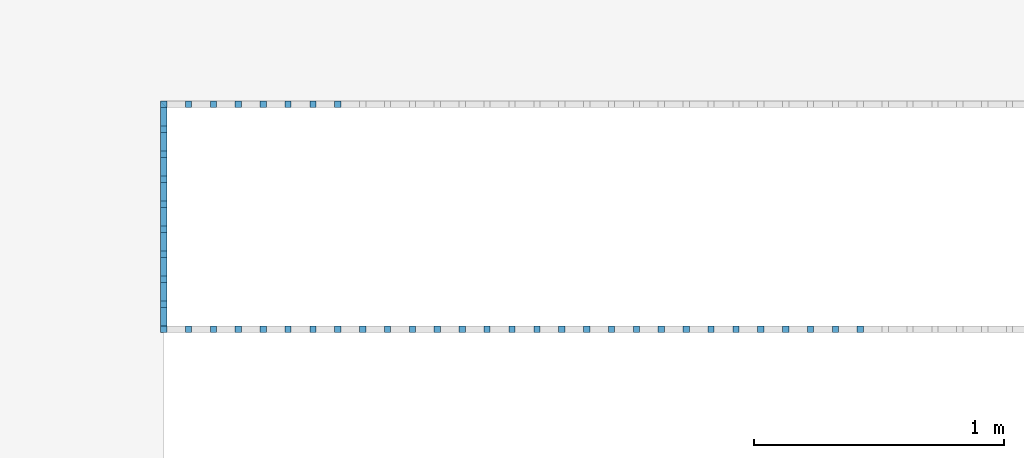
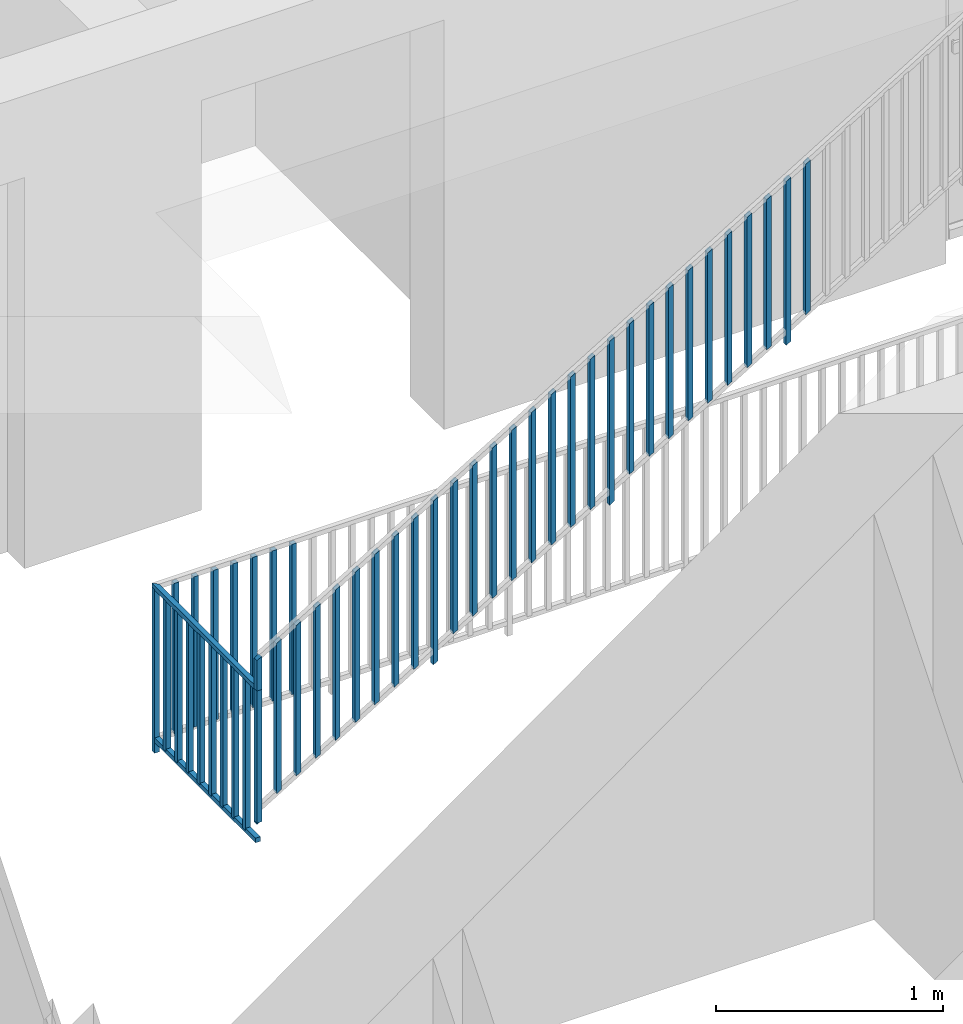
# One storey, part 39 of 54: 48 building element parts, 2 elements without a shape of their own.
"""IFC4 building model written with IfcOpenShell, lengths in metres."""

import ifcopenshell
import ifcopenshell.guid

model = None  # the IFC model being written
_history = None  # IfcOwnerHistory: only IFC2X3 demands one
_inside = {}  # id of a spatial element -> (the spatial element, [elements in it])
_under = {}  # id of a project, library or spatial element -> (it, [spatial elements below it])
_declared = {}  # id of a project -> (the project, [libraries it declares])
_typed = {}  # id of a type object -> (the type object, [elements of that type])
_made_of = {}  # id of a material, layer set ... -> (it, [elements and type objects made of it])


def new_model(schema):
    """Start an empty IFC model of exactly this schema.

    Asked for "IFC4X3", IfcOpenShell would pick the latest addendum, in which some entities
    have other attributes; the version numbers below select the first issue.
    IFC2X3 requires an IfcOwnerHistory on every rooted entity: one is made here for all.
    """
    global model, _history
    if schema == "IFC4X3":
        model = ifcopenshell.file(schema_version=(4, 3, 0, 0))
    else:
        model = ifcopenshell.file(schema=schema)
    _inside.clear()
    _under.clear()
    _declared.clear()
    _typed.clear()
    _made_of.clear()
    _history = None
    if model.schema == "IFC2X3":
        org = make("IfcOrganization", Name="unknown")
        user = make(
            "IfcPersonAndOrganization",
            ThePerson=make("IfcPerson", FamilyName="unknown"),
            TheOrganization=org,
        )
        app = make(
            "IfcApplication",
            ApplicationDeveloper=org,
            Version="unknown",
            ApplicationFullName="unknown",
            ApplicationIdentifier="unknown",
        )
        _history = make(
            "IfcOwnerHistory",
            OwningUser=user,
            OwningApplication=app,
            ChangeAction="ADDED",
            CreationDate=0,
        )
    return model


def make(cls, **values):
    """One entity of the class cls with the attributes given. An attribute that is None is left unset."""
    return model.create_entity(
        cls, **{name: value for name, value in values.items() if value is not None}
    )


def entity(cls, *values):
    """Any entity or typed value of the class cls, its attributes in the order of the schema. None: left unset."""
    e = model.create_entity(cls)
    for i, value in enumerate(values):
        if value is not None:
            e[i] = value
    return e


def rooted(cls, **values):
    """An entity with a GlobalId (a new one), such as an element, a storey or a relation."""
    return make(cls, GlobalId=ifcopenshell.guid.new(), OwnerHistory=_history, **values)


def si_unit(unit_type, name, prefix=None):
    """IfcSIUnit, for example si_unit("LENGTHUNIT", "METRE", prefix="MILLI")."""
    return make("IfcSIUnit", UnitType=unit_type, Prefix=prefix, Name=name)


def converted_unit(unit_type, name, factor, base, dimensions=None, offset=None):
    """IfcConversionBasedUnit, such as the inch: factor (a typed value) times the base unit."""
    return make(
        "IfcConversionBasedUnit"
        if offset is None
        else "IfcConversionBasedUnitWithOffset",
        ConversionOffset=offset,
        Dimensions=None
        if dimensions is None
        else entity("IfcDimensionalExponents", *dimensions),
        UnitType=unit_type,
        Name=name,
        ConversionFactor=make(
            "IfcMeasureWithUnit", ValueComponent=factor, UnitComponent=base
        ),
    )


def derived_unit(unit_type, elements):
    """IfcDerivedUnit: a product of units, each with its exponent."""
    return make(
        "IfcDerivedUnit",
        Elements=[
            make("IfcDerivedUnitElement", Unit=unit, Exponent=power)
            for unit, power in elements
        ],
        UnitType=unit_type,
    )


def assignment(units):
    """IfcUnitAssignment: the units of a project."""
    return None if units is None else make("IfcUnitAssignment", Units=units)


def point(xyz):
    """IfcCartesianPoint."""
    return None if xyz is None else make("IfcCartesianPoint", Coordinates=xyz)


def direction(xyz):
    """IfcDirection."""
    return None if xyz is None else make("IfcDirection", DirectionRatios=xyz)


def frame(location, z_axis=None, x_axis=None):
    """IfcAxis2Placement3D, a coordinate frame: its origin and axes. An axis left out is left unset."""
    return make(
        "IfcAxis2Placement3D",
        Location=point(location),
        Axis=direction(z_axis),
        RefDirection=direction(x_axis),
    )


def origin_with_axes():
    """The frame at (0, 0, 0) with the z axis (0, 0, 1) and the x axis (1, 0, 0) written out."""
    return frame((0.0, 0.0, 0.0), z_axis=(0.0, 0.0, 1.0), x_axis=(1.0, 0.0, 0.0))


def place(relative_to, where):
    """IfcLocalPlacement: puts the frame where relative to a parent placement (None: the world)."""
    return make(
        "IfcLocalPlacement", PlacementRelTo=relative_to, RelativePlacement=where
    )


def context(
    kind, dimensions, precision=None, world=None, true_north=None, identifier=None
):
    """IfcGeometricRepresentationContext, for example the 3D "Model" context."""
    return make(
        "IfcGeometricRepresentationContext",
        ContextIdentifier=identifier,
        ContextType=kind,
        CoordinateSpaceDimension=dimensions,
        Precision=precision,
        WorldCoordinateSystem=world,
        TrueNorth=true_north,
    )


def subcontext(parent, identifier, kind, view, scale=None):
    """IfcGeometricRepresentationSubContext, for example "Body" below "Model"."""
    return make(
        "IfcGeometricRepresentationSubContext",
        ContextIdentifier=identifier,
        ContextType=kind,
        ParentContext=parent,
        TargetScale=scale,
        TargetView=view,
    )


def project(units=None, contexts=None):
    """IfcProject with its units and contexts."""
    return rooted(
        "IfcProject",
        Name="project",
        RepresentationContexts=contexts,
        UnitsInContext=assignment(units),
    )


def spatial(cls, under=None, at=None, **own):
    """A site, building, storey or space (cls), placed at a placement, below another one or the project."""
    s = rooted(cls, ObjectPlacement=at, **own)
    if under is not None:
        _under.setdefault(under.id(), (under, []))[1].append(s)
    return s


def point_list(points):
    """IfcCartesianPointList2D or 3D."""
    cls = (
        "IfcCartesianPointList2D" if len(points[0]) == 2 else "IfcCartesianPointList3D"
    )
    return make(cls, CoordList=points)


def polygons(points, faces, closed=None, point_numbers=None):
    """IfcPolygonalFaceSet: a face is its outer loop, then its inner loops; points numbered from 1."""
    made = []
    for loops in faces:
        if len(loops) == 1:
            made.append(make("IfcIndexedPolygonalFace", CoordIndex=loops[0]))
        else:
            made.append(
                make(
                    "IfcIndexedPolygonalFaceWithVoids",
                    CoordIndex=loops[0],
                    InnerCoordIndices=loops[1:],
                )
            )
    return make(
        "IfcPolygonalFaceSet",
        Coordinates=point_list(points),
        Closed=closed,
        Faces=made,
        PnIndex=point_numbers,
    )


def shape(context_of_items, identifier, shape_type, items):
    """IfcShapeRepresentation: the items that make up one representation, for example the "Body"."""
    return make(
        "IfcShapeRepresentation",
        ContextOfItems=context_of_items,
        RepresentationIdentifier=identifier,
        RepresentationType=shape_type,
        Items=items,
    )


def material(Name=None, Category=None):
    """IfcMaterial."""
    return make("IfcMaterial", Name=Name, Category=Category)


def made_of(thing, what):
    """Note that an element or type object is made of a material, layer set ...; save() writes the relation."""
    if what is not None:
        _made_of.setdefault(what.id(), (what, []))[1].append(thing)
    return thing


def type_object(cls, material=None, **own):
    """A type object (cls), such as IfcWallType, which elements share."""
    return made_of(rooted(cls, **own), material)


def element(
    cls,
    number,
    at=None,
    inside=None,
    cuts=None,
    type_object=None,
    material=None,
    context=None,
    identifier="Body",
    shape_type=None,
    held_by="IfcProductDefinitionShape",
    body=None,
    shapes=None,
    **own,
):
    """One element of the class cls, such as IfcWall. Its Tag is "e" and its number.

    at: its placement. inside: the storey or other place that contains it. cuts: it is an
    opening in that element (IfcRelVoidsElement). A single representation is given by context,
    identifier, shape_type and body (its items); several are given by shapes. held_by: the class
    of the entity that holds the representations. save() writes the other relations.
    """
    e = rooted(cls, Tag="e%d" % number, ObjectPlacement=at, **own)
    if body is not None:
        shapes = [shape(context, identifier, shape_type, body)]
    if shapes is not None:
        e.Representation = make(held_by, Representations=shapes)
    if inside is not None:
        _inside.setdefault(inside.id(), (inside, []))[1].append(e)
    if cuts is not None:
        rooted(
            "IfcRelVoidsElement", RelatingBuildingElement=cuts, RelatedOpeningElement=e
        )
    if type_object is not None:
        _typed.setdefault(type_object.id(), (type_object, []))[1].append(e)
    return made_of(e, material)


def aggregate(whole, parts):
    """IfcRelAggregates: a whole, such as a stair, and the parts it consists of."""
    return rooted("IfcRelAggregates", RelatingObject=whole, RelatedObjects=parts)


def save(model, path):
    """Write the relations noted so far, then the file.

    IfcRelAggregates (storeys below a building ...), IfcRelContainedInSpatialStructure (elements
    in a storey), IfcRelDefinesByType, IfcRelAssociatesMaterial and IfcRelDeclares: one each for
    every whole, place, type object, material and project.
    """
    for whole, parts in _under.values():
        aggregate(whole, parts)
    for where, things in _inside.values():
        rooted(
            "IfcRelContainedInSpatialStructure",
            RelatedElements=things,
            RelatingStructure=where,
        )
    for kind, things in _typed.values():
        rooted("IfcRelDefinesByType", RelatedObjects=things, RelatingType=kind)
    for what, things in _made_of.values():
        rooted("IfcRelAssociatesMaterial", RelatedObjects=things, RelatingMaterial=what)
    for by, libraries in _declared.values():
        rooted("IfcRelDeclares", RelatingContext=by, RelatedDefinitions=libraries)
    model.write(path)


model = new_model("IFC4")

# Units and contexts
model_context = context("Model", 3, precision=1e-05, world=origin_with_axes(), true_north=direction((0.0, 1.0)))
body_context = subcontext(model_context, "Body", "Model", "MODEL_VIEW")
ifc_project = project(units=[si_unit("LENGTHUNIT", "METRE"), si_unit("AREAUNIT", "SQUARE_METRE"), si_unit("VOLUMEUNIT", "CUBIC_METRE"), converted_unit("PLANEANGLEUNIT", "DEGREE", entity("IfcPlaneAngleMeasure", 0.0174532925199), si_unit("PLANEANGLEUNIT", "RADIAN"), dimensions=[0, 0, 0, 0, 0, 0, 0]), converted_unit("TIMEUNIT", "Year", entity("IfcTimeMeasure", 31556926.0), si_unit("TIMEUNIT", "SECOND"), dimensions=[0, 0, 1, 0, 0, 0, 0]), si_unit("MASSUNIT", "GRAM", prefix="KILO"), si_unit("THERMODYNAMICTEMPERATUREUNIT", "DEGREE_CELSIUS"), si_unit("LUMINOUSINTENSITYUNIT", "LUMEN"), si_unit("ENERGYUNIT", "JOULE", prefix="MEGA"), derived_unit("THERMALCONDUCTANCEUNIT", [(si_unit("POWERUNIT", "WATT"), 1), (si_unit("LENGTHUNIT", "METRE"), -1), (si_unit("THERMODYNAMICTEMPERATUREUNIT", "KELVIN"), -1)]), derived_unit("SPECIFICHEATCAPACITYUNIT", [(si_unit("ENERGYUNIT", "JOULE"), 1), (si_unit("MASSUNIT", "GRAM", prefix="KILO"), -1), (si_unit("THERMODYNAMICTEMPERATUREUNIT", "KELVIN"), -1)]), derived_unit("MASSDENSITYUNIT", [(si_unit("MASSUNIT", "GRAM", prefix="KILO"), 1), (si_unit("VOLUMEUNIT", "CUBIC_METRE"), -1)])], contexts=[model_context])

# Site, building, storey, space
site_placement = place(None, origin_with_axes())
site = spatial("IfcSite", under=ifc_project, at=site_placement, CompositionType="ELEMENT")
building_placement = place(site_placement, origin_with_axes())
building = spatial("IfcBuilding", under=site, at=building_placement, CompositionType="ELEMENT")
storey_placement = place(building_placement, frame((0.0, 0.0, 6.29), z_axis=(0.0, 0.0, 1.0), x_axis=(1.0, 0.0, 0.0)))
storey = spatial("IfcBuildingStorey", under=building, at=storey_placement, Name="2. Geschoss", CompositionType="ELEMENT", Elevation=6.29)
space_placement = place(storey_placement, frame((-3.4421993804, -2.52881223104, 0.0), z_axis=(0.0, 0.0, 1.0), x_axis=(1.0, 0.0, 0.0)))
space = spatial("IfcSpace", under=storey, at=space_placement, CompositionType="ELEMENT", PredefinedType="INTERNAL")

# Railing, building element parts
railing_type = type_object("IfcRailingType", PredefinedType="NOTDEFINED")
railing_1_placement = place(space_placement, frame((0.0, 1.5, 0.0), z_axis=(0.0, 0.0, 1.0), x_axis=(1.0, 0.0, 0.0)))
railing_1 = element("IfcRailing", 1, at=railing_1_placement, inside=space, type_object=railing_type, PredefinedType="NOTDEFINED")
ifc_material = material()
building_element_part_1_placement = place(railing_1_placement, origin_with_axes())
building_element_part_1 = element("IfcBuildingElementPart", 2, at=building_element_part_1_placement, material=ifc_material, PredefinedType="NOTDEFINED", context=body_context, shape_type="Tessellation", body=[
    polygons([(0.0125, 0.0125, 0.17), (-0.0125, 0.0125, 0.17), (-0.0125, 0.0125, 0.88), (0.0125, 0.0125, 0.88), (0.0125, -0.0125, 0.17), (-0.0125, -0.0125, 0.17), (-0.0125, -0.0125, 0.88), (0.0125, -0.0125, 0.88)], [[[1, 2, 3, 4]], [[1, 5, 6, 2]], [[2, 6, 7, 3]], [[4, 3, 7, 8]], [[5, 1, 4, 8]], [[6, 5, 8, 7]]], closed=True),
])
building_element_part_2_placement = place(railing_1_placement, origin_with_axes())
building_element_part_2 = element("IfcBuildingElementPart", 3, at=building_element_part_2_placement, material=ifc_material, PredefinedType="NOTDEFINED", context=body_context, shape_type="Tessellation", body=[
    polygons([(0.0125, 0.9125, 0.0), (-0.0125, 0.9125, 0.0), (-0.0125, 0.9125, 0.88), (0.0125, 0.9125, 0.88), (0.0125, 0.8875, 0.0), (-0.0125, 0.8875, 0.0), (-0.0125, 0.8875, 0.88), (0.0125, 0.8875, 0.88)], [[[1, 2, 3, 4]], [[1, 5, 6, 2]], [[2, 6, 7, 3]], [[4, 3, 7, 8]], [[5, 1, 4, 8]], [[6, 5, 8, 7]]], closed=True),
])
building_element_part_3_placement = place(railing_1_placement, origin_with_axes())
building_element_part_3 = element("IfcBuildingElementPart", 4, at=building_element_part_3_placement, material=ifc_material, PredefinedType="NOTDEFINED", context=body_context, shape_type="Tessellation", body=[
    polygons([(0.0125, 0.0, 0.9), (0.0125, 0.0, 0.875), (0.0125, 0.8875, 0.875), (0.0125, 0.8875, 0.9), (-0.0125, 0.0, 0.9), (-0.0125, 0.0, 0.875), (-0.0125, 0.9125, 0.875), (-0.0125, 0.9125, 0.9)], [[[1, 2, 3, 4]], [[1, 5, 6, 2]], [[2, 6, 7, 3]], [[4, 3, 7, 8]], [[5, 1, 4, 8]], [[6, 5, 8, 7]]], closed=True),
])
building_element_part_4_placement = place(railing_1_placement, origin_with_axes())
building_element_part_4 = element("IfcBuildingElementPart", 5, at=building_element_part_4_placement, material=ifc_material, PredefinedType="NOTDEFINED", context=body_context, shape_type="Tessellation", body=[
    polygons([(0.0125, 0.0, 0.0825), (0.0125, 0.0, 0.0575), (0.0125, 0.8875, 0.0575), (0.0125, 0.8875, 0.0825), (-0.0125, 0.0, 0.0825), (-0.0125, 0.0, 0.0575), (-0.0125, 0.9125, 0.0575), (-0.0125, 0.9125, 0.0825)], [[[1, 2, 3, 4]], [[1, 5, 6, 2]], [[2, 6, 7, 3]], [[4, 3, 7, 8]], [[5, 1, 4, 8]], [[6, 5, 8, 7]]], closed=True),
])
building_element_part_5_placement = place(railing_1_placement, origin_with_axes())
building_element_part_5 = element("IfcBuildingElementPart", 6, at=building_element_part_5_placement, material=ifc_material, PredefinedType="NOTDEFINED", context=body_context, shape_type="Tessellation", body=[
    polygons([(0.0125, 0.1125, 0.07), (-0.0125, 0.1125, 0.07), (-0.0125, 0.1125, 0.8775), (0.0125, 0.1125, 0.8775), (0.0125, 0.0875, 0.07), (-0.0125, 0.0875, 0.07), (-0.0125, 0.0875, 0.8775), (0.0125, 0.0875, 0.8775)], [[[1, 2, 3, 4]], [[1, 5, 6, 2]], [[2, 6, 7, 3]], [[4, 3, 7, 8]], [[5, 1, 4, 8]], [[6, 5, 8, 7]]], closed=True),
])
building_element_part_6_placement = place(railing_1_placement, origin_with_axes())
building_element_part_6 = element("IfcBuildingElementPart", 7, at=building_element_part_6_placement, material=ifc_material, PredefinedType="NOTDEFINED", context=body_context, shape_type="Tessellation", body=[
    polygons([(0.0125, 0.2125, 0.07), (-0.0125, 0.2125, 0.07), (-0.0125, 0.2125, 0.8775), (0.0125, 0.2125, 0.8775), (0.0125, 0.1875, 0.07), (-0.0125, 0.1875, 0.07), (-0.0125, 0.1875, 0.8775), (0.0125, 0.1875, 0.8775)], [[[1, 2, 3, 4]], [[1, 5, 6, 2]], [[2, 6, 7, 3]], [[4, 3, 7, 8]], [[5, 1, 4, 8]], [[6, 5, 8, 7]]], closed=True),
])
building_element_part_7_placement = place(railing_1_placement, origin_with_axes())
building_element_part_7 = element("IfcBuildingElementPart", 8, at=building_element_part_7_placement, material=ifc_material, PredefinedType="NOTDEFINED", context=body_context, shape_type="Tessellation", body=[
    polygons([(0.0125, 0.3125, 0.07), (-0.0125, 0.3125, 0.07), (-0.0125, 0.3125, 0.8775), (0.0125, 0.3125, 0.8775), (0.0125, 0.2875, 0.07), (-0.0125, 0.2875, 0.07), (-0.0125, 0.2875, 0.8775), (0.0125, 0.2875, 0.8775)], [[[1, 2, 3, 4]], [[1, 5, 6, 2]], [[2, 6, 7, 3]], [[4, 3, 7, 8]], [[5, 1, 4, 8]], [[6, 5, 8, 7]]], closed=True),
])
building_element_part_8_placement = place(railing_1_placement, origin_with_axes())
building_element_part_8 = element("IfcBuildingElementPart", 9, at=building_element_part_8_placement, material=ifc_material, PredefinedType="NOTDEFINED", context=body_context, shape_type="Tessellation", body=[
    polygons([(0.0125, 0.4125, 0.07), (-0.0125, 0.4125, 0.07), (-0.0125, 0.4125, 0.8775), (0.0125, 0.4125, 0.8775), (0.0125, 0.3875, 0.07), (-0.0125, 0.3875, 0.07), (-0.0125, 0.3875, 0.8775), (0.0125, 0.3875, 0.8775)], [[[1, 2, 3, 4]], [[1, 5, 6, 2]], [[2, 6, 7, 3]], [[4, 3, 7, 8]], [[5, 1, 4, 8]], [[6, 5, 8, 7]]], closed=True),
])
building_element_part_9_placement = place(railing_1_placement, origin_with_axes())
building_element_part_9 = element("IfcBuildingElementPart", 10, at=building_element_part_9_placement, material=ifc_material, PredefinedType="NOTDEFINED", context=body_context, shape_type="Tessellation", body=[
    polygons([(0.0125, 0.5125, 0.07), (-0.0125, 0.5125, 0.07), (-0.0125, 0.5125, 0.8775), (0.0125, 0.5125, 0.8775), (0.0125, 0.4875, 0.07), (-0.0125, 0.4875, 0.07), (-0.0125, 0.4875, 0.8775), (0.0125, 0.4875, 0.8775)], [[[1, 2, 3, 4]], [[1, 5, 6, 2]], [[2, 6, 7, 3]], [[4, 3, 7, 8]], [[5, 1, 4, 8]], [[6, 5, 8, 7]]], closed=True),
])
building_element_part_10_placement = place(railing_1_placement, origin_with_axes())
building_element_part_10 = element("IfcBuildingElementPart", 11, at=building_element_part_10_placement, material=ifc_material, PredefinedType="NOTDEFINED", context=body_context, shape_type="Tessellation", body=[
    polygons([(0.0125, 0.6125, 0.07), (-0.0125, 0.6125, 0.07), (-0.0125, 0.6125, 0.8775), (0.0125, 0.6125, 0.8775), (0.0125, 0.5875, 0.07), (-0.0125, 0.5875, 0.07), (-0.0125, 0.5875, 0.8775), (0.0125, 0.5875, 0.8775)], [[[1, 2, 3, 4]], [[1, 5, 6, 2]], [[2, 6, 7, 3]], [[4, 3, 7, 8]], [[5, 1, 4, 8]], [[6, 5, 8, 7]]], closed=True),
])
building_element_part_11_placement = place(railing_1_placement, origin_with_axes())
building_element_part_11 = element("IfcBuildingElementPart", 12, at=building_element_part_11_placement, material=ifc_material, PredefinedType="NOTDEFINED", context=body_context, shape_type="Tessellation", body=[
    polygons([(0.0125, 0.7125, 0.07), (-0.0125, 0.7125, 0.07), (-0.0125, 0.7125, 0.8775), (0.0125, 0.7125, 0.8775), (0.0125, 0.6875, 0.07), (-0.0125, 0.6875, 0.07), (-0.0125, 0.6875, 0.8775), (0.0125, 0.6875, 0.8775)], [[[1, 2, 3, 4]], [[1, 5, 6, 2]], [[2, 6, 7, 3]], [[4, 3, 7, 8]], [[5, 1, 4, 8]], [[6, 5, 8, 7]]], closed=True),
])
building_element_part_12_placement = place(railing_1_placement, origin_with_axes())
building_element_part_12 = element("IfcBuildingElementPart", 13, at=building_element_part_12_placement, material=ifc_material, PredefinedType="NOTDEFINED", context=body_context, shape_type="Tessellation", body=[
    polygons([(0.0125, 0.8125, 0.07), (-0.0125, 0.8125, 0.07), (-0.0125, 0.8125, 0.8775), (0.0125, 0.8125, 0.8775), (0.0125, 0.7875, 0.07), (-0.0125, 0.7875, 0.07), (-0.0125, 0.7875, 0.8775), (0.0125, 0.7875, 0.8775)], [[[1, 2, 3, 4]], [[1, 5, 6, 2]], [[2, 6, 7, 3]], [[4, 3, 7, 8]], [[5, 1, 4, 8]], [[6, 5, 8, 7]]], closed=True),
])
building_element_part_13_placement = place(railing_1_placement, origin_with_axes())
building_element_part_13 = element("IfcBuildingElementPart", 14, at=building_element_part_13_placement, material=ifc_material, PredefinedType="NOTDEFINED", context=body_context, shape_type="Tessellation", body=[
    polygons([(0.112055555556, 0.8875, 0.07), (0.112055555556, 0.9125, 0.07), (0.112055555556, 0.9125, 0.8775), (0.112055555556, 0.8875, 0.8775), (0.0870555555556, 0.8875, 0.07), (0.0870555555556, 0.9125, 0.07), (0.0870555555556, 0.9125, 0.8775), (0.0870555555556, 0.8875, 0.8775)], [[[1, 2, 3, 4]], [[1, 5, 6, 2]], [[2, 6, 7, 3]], [[4, 3, 7, 8]], [[5, 1, 4, 8]], [[6, 5, 8, 7]]], closed=True),
])
building_element_part_14_placement = place(railing_1_placement, origin_with_axes())
building_element_part_14 = element("IfcBuildingElementPart", 15, at=building_element_part_14_placement, material=ifc_material, PredefinedType="NOTDEFINED", context=body_context, shape_type="Tessellation", body=[
    polygons([(0.211611111111, 0.8875, 0.07), (0.211611111111, 0.9125, 0.07), (0.211611111111, 0.9125, 0.8775), (0.211611111111, 0.8875, 0.8775), (0.186611111111, 0.8875, 0.07), (0.186611111111, 0.9125, 0.07), (0.186611111111, 0.9125, 0.8775), (0.186611111111, 0.8875, 0.8775)], [[[1, 2, 3, 4]], [[1, 5, 6, 2]], [[2, 6, 7, 3]], [[4, 3, 7, 8]], [[5, 1, 4, 8]], [[6, 5, 8, 7]]], closed=True),
])
building_element_part_15_placement = place(railing_1_placement, origin_with_axes())
building_element_part_15 = element("IfcBuildingElementPart", 16, at=building_element_part_15_placement, material=ifc_material, PredefinedType="NOTDEFINED", context=body_context, shape_type="Tessellation", body=[
    polygons([(0.311166666667, 0.8875, 0.07), (0.311166666667, 0.9125, 0.07), (0.311166666667, 0.9125, 0.8775), (0.311166666667, 0.8875, 0.8775), (0.286166666667, 0.8875, 0.07), (0.286166666667, 0.9125, 0.07), (0.286166666667, 0.9125, 0.8775), (0.286166666667, 0.8875, 0.8775)], [[[1, 2, 3, 4]], [[1, 5, 6, 2]], [[2, 6, 7, 3]], [[4, 3, 7, 8]], [[5, 1, 4, 8]], [[6, 5, 8, 7]]], closed=True),
])
building_element_part_16_placement = place(railing_1_placement, origin_with_axes())
building_element_part_16 = element("IfcBuildingElementPart", 17, at=building_element_part_16_placement, material=ifc_material, PredefinedType="NOTDEFINED", context=body_context, shape_type="Tessellation", body=[
    polygons([(0.410722222222, 0.8875, 0.07), (0.410722222222, 0.9125, 0.07), (0.410722222222, 0.9125, 0.8775), (0.410722222222, 0.8875, 0.8775), (0.385722222222, 0.8875, 0.07), (0.385722222222, 0.9125, 0.07), (0.385722222222, 0.9125, 0.8775), (0.385722222222, 0.8875, 0.8775)], [[[1, 2, 3, 4]], [[1, 5, 6, 2]], [[2, 6, 7, 3]], [[4, 3, 7, 8]], [[5, 1, 4, 8]], [[6, 5, 8, 7]]], closed=True),
])
building_element_part_17_placement = place(railing_1_placement, origin_with_axes())
building_element_part_17 = element("IfcBuildingElementPart", 18, at=building_element_part_17_placement, material=ifc_material, PredefinedType="NOTDEFINED", context=body_context, shape_type="Tessellation", body=[
    polygons([(0.510277777778, 0.8875, 0.07), (0.510277777778, 0.9125, 0.07), (0.510277777778, 0.9125, 0.8775), (0.510277777778, 0.8875, 0.8775), (0.485277777778, 0.8875, 0.07), (0.485277777778, 0.9125, 0.07), (0.485277777778, 0.9125, 0.8775), (0.485277777778, 0.8875, 0.8775)], [[[1, 2, 3, 4]], [[1, 5, 6, 2]], [[2, 6, 7, 3]], [[4, 3, 7, 8]], [[5, 1, 4, 8]], [[6, 5, 8, 7]]], closed=True),
])
building_element_part_18_placement = place(railing_1_placement, origin_with_axes())
building_element_part_18 = element("IfcBuildingElementPart", 19, at=building_element_part_18_placement, material=ifc_material, PredefinedType="NOTDEFINED", context=body_context, shape_type="Tessellation", body=[
    polygons([(0.609833333333, 0.8875, 0.07), (0.609833333333, 0.9125, 0.07), (0.609833333333, 0.9125, 0.8775), (0.609833333333, 0.8875, 0.8775), (0.584833333333, 0.8875, 0.07), (0.584833333333, 0.9125, 0.07), (0.584833333333, 0.9125, 0.8775), (0.584833333333, 0.8875, 0.8775)], [[[1, 2, 3, 4]], [[1, 5, 6, 2]], [[2, 6, 7, 3]], [[4, 3, 7, 8]], [[5, 1, 4, 8]], [[6, 5, 8, 7]]], closed=True),
])
building_element_part_19_placement = place(railing_1_placement, origin_with_axes())
building_element_part_19 = element("IfcBuildingElementPart", 20, at=building_element_part_19_placement, material=ifc_material, PredefinedType="NOTDEFINED", context=body_context, shape_type="Tessellation", body=[
    polygons([(0.709388888889, 0.8875, 0.07), (0.709388888889, 0.9125, 0.07), (0.709388888889, 0.9125, 0.8775), (0.709388888889, 0.8875, 0.8775), (0.684388888889, 0.8875, 0.07), (0.684388888889, 0.9125, 0.07), (0.684388888889, 0.9125, 0.8775), (0.684388888889, 0.8875, 0.8775)], [[[1, 2, 3, 4]], [[1, 5, 6, 2]], [[2, 6, 7, 3]], [[4, 3, 7, 8]], [[5, 1, 4, 8]], [[6, 5, 8, 7]]], closed=True),
])
aggregate(railing_1, [building_element_part_1, building_element_part_2, building_element_part_3, building_element_part_4, building_element_part_5, building_element_part_6, building_element_part_7, building_element_part_8, building_element_part_9, building_element_part_10, building_element_part_11, building_element_part_12, building_element_part_13, building_element_part_14, building_element_part_15, building_element_part_16, building_element_part_17, building_element_part_18, building_element_part_19])

railing_2_placement = place(space_placement, frame((0.0, 1.5, 0.17), z_axis=(0.0, 0.0, 1.0), x_axis=(1.0, 0.0, 0.0)))
railing_2 = element("IfcRailing", 21, at=railing_2_placement, inside=space, type_object=railing_type, PredefinedType="NOTDEFINED")
building_element_part_20_placement = place(railing_2_placement, origin_with_axes())
building_element_part_20 = element("IfcBuildingElementPart", 22, at=building_element_part_20_placement, material=ifc_material, PredefinedType="NOTDEFINED", context=body_context, shape_type="Tessellation", body=[
    polygons([(0.0125, -0.0125, 0.00758928571429), (0.0125, 0.0125, 0.00758928571429), (0.0125, 0.0125, 0.887589285714), (0.0125, -0.0125, 0.887589285714), (-0.0125, -0.0125, -0.00758928571429), (-0.0125, 0.0125, -0.00758928571429), (-0.0125, 0.0125, 0.872410714286), (-0.0125, -0.0125, 0.872410714286)], [[[1, 2, 3, 4]], [[1, 5, 6, 2]], [[2, 6, 7, 3]], [[4, 3, 7, 8]], [[5, 1, 4, 8]], [[6, 5, 8, 7]]], closed=True),
])
building_element_part_21_placement = place(railing_2_placement, origin_with_axes())
building_element_part_21 = element("IfcBuildingElementPart", 23, at=building_element_part_21_placement, material=ifc_material, PredefinedType="NOTDEFINED", context=body_context, shape_type="Tessellation", body=[
    polygons([(0.112055555556, -0.0125, 0.138033730159), (0.112055555556, 0.0125, 0.138033730159), (0.112055555556, 0.0125, 0.945533730159), (0.112055555556, -0.0125, 0.945533730159), (0.0870555555556, -0.0125, 0.12285515873), (0.0870555555556, 0.0125, 0.12285515873), (0.0870555555556, 0.0125, 0.93035515873), (0.0870555555556, -0.0125, 0.93035515873)], [[[1, 2, 3, 4]], [[1, 5, 6, 2]], [[2, 6, 7, 3]], [[4, 3, 7, 8]], [[5, 1, 4, 8]], [[6, 5, 8, 7]]], closed=True),
])
building_element_part_22_placement = place(railing_2_placement, origin_with_axes())
building_element_part_22 = element("IfcBuildingElementPart", 24, at=building_element_part_22_placement, material=ifc_material, PredefinedType="NOTDEFINED", context=body_context, shape_type="Tessellation", body=[
    polygons([(0.211611111111, -0.0125, 0.198478174603), (0.211611111111, 0.0125, 0.198478174603), (0.211611111111, 0.0125, 1.0059781746), (0.211611111111, -0.0125, 1.0059781746), (0.186611111111, -0.0125, 0.183299603175), (0.186611111111, 0.0125, 0.183299603175), (0.186611111111, 0.0125, 0.990799603175), (0.186611111111, -0.0125, 0.990799603175)], [[[1, 2, 3, 4]], [[1, 5, 6, 2]], [[2, 6, 7, 3]], [[4, 3, 7, 8]], [[5, 1, 4, 8]], [[6, 5, 8, 7]]], closed=True),
])
building_element_part_23_placement = place(railing_2_placement, origin_with_axes())
building_element_part_23 = element("IfcBuildingElementPart", 25, at=building_element_part_23_placement, material=ifc_material, PredefinedType="NOTDEFINED", context=body_context, shape_type="Tessellation", body=[
    polygons([(0.311166666667, -0.0125, 0.258922619048), (0.311166666667, 0.0125, 0.258922619048), (0.311166666667, 0.0125, 1.06642261905), (0.311166666667, -0.0125, 1.06642261905), (0.286166666667, -0.0125, 0.243744047619), (0.286166666667, 0.0125, 0.243744047619), (0.286166666667, 0.0125, 1.05124404762), (0.286166666667, -0.0125, 1.05124404762)], [[[1, 2, 3, 4]], [[1, 5, 6, 2]], [[2, 6, 7, 3]], [[4, 3, 7, 8]], [[5, 1, 4, 8]], [[6, 5, 8, 7]]], closed=True),
])
building_element_part_24_placement = place(railing_2_placement, origin_with_axes())
building_element_part_24 = element("IfcBuildingElementPart", 26, at=building_element_part_24_placement, material=ifc_material, PredefinedType="NOTDEFINED", context=body_context, shape_type="Tessellation", body=[
    polygons([(0.410722222222, -0.0125, 0.319367063492), (0.410722222222, 0.0125, 0.319367063492), (0.410722222222, 0.0125, 1.12686706349), (0.410722222222, -0.0125, 1.12686706349), (0.385722222222, -0.0125, 0.304188492063), (0.385722222222, 0.0125, 0.304188492063), (0.385722222222, 0.0125, 1.11168849206), (0.385722222222, -0.0125, 1.11168849206)], [[[1, 2, 3, 4]], [[1, 5, 6, 2]], [[2, 6, 7, 3]], [[4, 3, 7, 8]], [[5, 1, 4, 8]], [[6, 5, 8, 7]]], closed=True),
])
building_element_part_25_placement = place(railing_2_placement, origin_with_axes())
building_element_part_25 = element("IfcBuildingElementPart", 27, at=building_element_part_25_placement, material=ifc_material, PredefinedType="NOTDEFINED", context=body_context, shape_type="Tessellation", body=[
    polygons([(0.510277777778, -0.0125, 0.379811507937), (0.510277777778, 0.0125, 0.379811507937), (0.510277777778, 0.0125, 1.18731150794), (0.510277777778, -0.0125, 1.18731150794), (0.485277777778, -0.0125, 0.364632936508), (0.485277777778, 0.0125, 0.364632936508), (0.485277777778, 0.0125, 1.17213293651), (0.485277777778, -0.0125, 1.17213293651)], [[[1, 2, 3, 4]], [[1, 5, 6, 2]], [[2, 6, 7, 3]], [[4, 3, 7, 8]], [[5, 1, 4, 8]], [[6, 5, 8, 7]]], closed=True),
])
building_element_part_26_placement = place(railing_2_placement, origin_with_axes())
building_element_part_26 = element("IfcBuildingElementPart", 28, at=building_element_part_26_placement, material=ifc_material, PredefinedType="NOTDEFINED", context=body_context, shape_type="Tessellation", body=[
    polygons([(0.609833333333, -0.0125, 0.440255952381), (0.609833333333, 0.0125, 0.440255952381), (0.609833333333, 0.0125, 1.24775595238), (0.609833333333, -0.0125, 1.24775595238), (0.584833333333, -0.0125, 0.425077380952), (0.584833333333, 0.0125, 0.425077380952), (0.584833333333, 0.0125, 1.23257738095), (0.584833333333, -0.0125, 1.23257738095)], [[[1, 2, 3, 4]], [[1, 5, 6, 2]], [[2, 6, 7, 3]], [[4, 3, 7, 8]], [[5, 1, 4, 8]], [[6, 5, 8, 7]]], closed=True),
])
building_element_part_27_placement = place(railing_2_placement, origin_with_axes())
building_element_part_27 = element("IfcBuildingElementPart", 29, at=building_element_part_27_placement, material=ifc_material, PredefinedType="NOTDEFINED", context=body_context, shape_type="Tessellation", body=[
    polygons([(0.709388888889, -0.0125, 0.500700396825), (0.709388888889, 0.0125, 0.500700396825), (0.709388888889, 0.0125, 1.30820039683), (0.709388888889, -0.0125, 1.30820039683), (0.684388888889, -0.0125, 0.485521825397), (0.684388888889, 0.0125, 0.485521825397), (0.684388888889, 0.0125, 1.2930218254), (0.684388888889, -0.0125, 1.2930218254)], [[[1, 2, 3, 4]], [[1, 5, 6, 2]], [[2, 6, 7, 3]], [[4, 3, 7, 8]], [[5, 1, 4, 8]], [[6, 5, 8, 7]]], closed=True),
])
building_element_part_28_placement = place(railing_2_placement, origin_with_axes())
building_element_part_28 = element("IfcBuildingElementPart", 30, at=building_element_part_28_placement, material=ifc_material, PredefinedType="NOTDEFINED", context=body_context, shape_type="Tessellation", body=[
    polygons([(0.808944444444, -0.0125, 0.56114484127), (0.808944444444, 0.0125, 0.56114484127), (0.808944444444, 0.0125, 1.36864484127), (0.808944444444, -0.0125, 1.36864484127), (0.783944444444, -0.0125, 0.545966269841), (0.783944444444, 0.0125, 0.545966269841), (0.783944444444, 0.0125, 1.35346626984), (0.783944444444, -0.0125, 1.35346626984)], [[[1, 2, 3, 4]], [[1, 5, 6, 2]], [[2, 6, 7, 3]], [[4, 3, 7, 8]], [[5, 1, 4, 8]], [[6, 5, 8, 7]]], closed=True),
])
building_element_part_29_placement = place(railing_2_placement, origin_with_axes())
building_element_part_29 = element("IfcBuildingElementPart", 31, at=building_element_part_29_placement, material=ifc_material, PredefinedType="NOTDEFINED", context=body_context, shape_type="Tessellation", body=[
    polygons([(0.9085, -0.0125, 0.551589285714), (0.9085, 0.0125, 0.551589285714), (0.9085, 0.0125, 1.43158928571), (0.9085, -0.0125, 1.43158928571), (0.8835, -0.0125, 0.536410714286), (0.8835, 0.0125, 0.536410714286), (0.8835, 0.0125, 1.41641071429), (0.8835, -0.0125, 1.41641071429)], [[[1, 2, 3, 4]], [[1, 5, 6, 2]], [[2, 6, 7, 3]], [[4, 3, 7, 8]], [[5, 1, 4, 8]], [[6, 5, 8, 7]]], closed=True),
])
building_element_part_30_placement = place(railing_2_placement, origin_with_axes())
building_element_part_30 = element("IfcBuildingElementPart", 32, at=building_element_part_30_placement, material=ifc_material, PredefinedType="NOTDEFINED", context=body_context, shape_type="Tessellation", body=[
    polygons([(1.00805555556, -0.0125, 0.682033730159), (1.00805555556, 0.0125, 0.682033730159), (1.00805555556, 0.0125, 1.48953373016), (1.00805555556, -0.0125, 1.48953373016), (0.983055555556, -0.0125, 0.66685515873), (0.983055555556, 0.0125, 0.66685515873), (0.983055555556, 0.0125, 1.47435515873), (0.983055555556, -0.0125, 1.47435515873)], [[[1, 2, 3, 4]], [[1, 5, 6, 2]], [[2, 6, 7, 3]], [[4, 3, 7, 8]], [[5, 1, 4, 8]], [[6, 5, 8, 7]]], closed=True),
])
building_element_part_31_placement = place(railing_2_placement, origin_with_axes())
building_element_part_31 = element("IfcBuildingElementPart", 33, at=building_element_part_31_placement, material=ifc_material, PredefinedType="NOTDEFINED", context=body_context, shape_type="Tessellation", body=[
    polygons([(1.10761111111, -0.0125, 0.742478174603), (1.10761111111, 0.0125, 0.742478174603), (1.10761111111, 0.0125, 1.5499781746), (1.10761111111, -0.0125, 1.5499781746), (1.08261111111, -0.0125, 0.727299603175), (1.08261111111, 0.0125, 0.727299603175), (1.08261111111, 0.0125, 1.53479960317), (1.08261111111, -0.0125, 1.53479960317)], [[[1, 2, 3, 4]], [[1, 5, 6, 2]], [[2, 6, 7, 3]], [[4, 3, 7, 8]], [[5, 1, 4, 8]], [[6, 5, 8, 7]]], closed=True),
])
building_element_part_32_placement = place(railing_2_placement, origin_with_axes())
building_element_part_32 = element("IfcBuildingElementPart", 34, at=building_element_part_32_placement, material=ifc_material, PredefinedType="NOTDEFINED", context=body_context, shape_type="Tessellation", body=[
    polygons([(1.20716666667, -0.0125, 0.802922619048), (1.20716666667, 0.0125, 0.802922619048), (1.20716666667, 0.0125, 1.61042261905), (1.20716666667, -0.0125, 1.61042261905), (1.18216666667, -0.0125, 0.787744047619), (1.18216666667, 0.0125, 0.787744047619), (1.18216666667, 0.0125, 1.59524404762), (1.18216666667, -0.0125, 1.59524404762)], [[[1, 2, 3, 4]], [[1, 5, 6, 2]], [[2, 6, 7, 3]], [[4, 3, 7, 8]], [[5, 1, 4, 8]], [[6, 5, 8, 7]]], closed=True),
])
building_element_part_33_placement = place(railing_2_placement, origin_with_axes())
building_element_part_33 = element("IfcBuildingElementPart", 35, at=building_element_part_33_placement, material=ifc_material, PredefinedType="NOTDEFINED", context=body_context, shape_type="Tessellation", body=[
    polygons([(1.30672222222, -0.0125, 0.863367063492), (1.30672222222, 0.0125, 0.863367063492), (1.30672222222, 0.0125, 1.67086706349), (1.30672222222, -0.0125, 1.67086706349), (1.28172222222, -0.0125, 0.848188492063), (1.28172222222, 0.0125, 0.848188492063), (1.28172222222, 0.0125, 1.65568849206), (1.28172222222, -0.0125, 1.65568849206)], [[[1, 2, 3, 4]], [[1, 5, 6, 2]], [[2, 6, 7, 3]], [[4, 3, 7, 8]], [[5, 1, 4, 8]], [[6, 5, 8, 7]]], closed=True),
])
building_element_part_34_placement = place(railing_2_placement, origin_with_axes())
building_element_part_34 = element("IfcBuildingElementPart", 36, at=building_element_part_34_placement, material=ifc_material, PredefinedType="NOTDEFINED", context=body_context, shape_type="Tessellation", body=[
    polygons([(1.40627777778, -0.0125, 0.923811507937), (1.40627777778, 0.0125, 0.923811507937), (1.40627777778, 0.0125, 1.73131150794), (1.40627777778, -0.0125, 1.73131150794), (1.38127777778, -0.0125, 0.908632936508), (1.38127777778, 0.0125, 0.908632936508), (1.38127777778, 0.0125, 1.71613293651), (1.38127777778, -0.0125, 1.71613293651)], [[[1, 2, 3, 4]], [[1, 5, 6, 2]], [[2, 6, 7, 3]], [[4, 3, 7, 8]], [[5, 1, 4, 8]], [[6, 5, 8, 7]]], closed=True),
])
building_element_part_35_placement = place(railing_2_placement, origin_with_axes())
building_element_part_35 = element("IfcBuildingElementPart", 37, at=building_element_part_35_placement, material=ifc_material, PredefinedType="NOTDEFINED", context=body_context, shape_type="Tessellation", body=[
    polygons([(1.50583333333, -0.0125, 0.984255952381), (1.50583333333, 0.0125, 0.984255952381), (1.50583333333, 0.0125, 1.79175595238), (1.50583333333, -0.0125, 1.79175595238), (1.48083333333, -0.0125, 0.969077380952), (1.48083333333, 0.0125, 0.969077380952), (1.48083333333, 0.0125, 1.77657738095), (1.48083333333, -0.0125, 1.77657738095)], [[[1, 2, 3, 4]], [[1, 5, 6, 2]], [[2, 6, 7, 3]], [[4, 3, 7, 8]], [[5, 1, 4, 8]], [[6, 5, 8, 7]]], closed=True),
])
building_element_part_36_placement = place(railing_2_placement, origin_with_axes())
building_element_part_36 = element("IfcBuildingElementPart", 38, at=building_element_part_36_placement, material=ifc_material, PredefinedType="NOTDEFINED", context=body_context, shape_type="Tessellation", body=[
    polygons([(1.60538888889, -0.0125, 1.04470039683), (1.60538888889, 0.0125, 1.04470039683), (1.60538888889, 0.0125, 1.85220039683), (1.60538888889, -0.0125, 1.85220039683), (1.58038888889, -0.0125, 1.0295218254), (1.58038888889, 0.0125, 1.0295218254), (1.58038888889, 0.0125, 1.8370218254), (1.58038888889, -0.0125, 1.8370218254)], [[[1, 2, 3, 4]], [[1, 5, 6, 2]], [[2, 6, 7, 3]], [[4, 3, 7, 8]], [[5, 1, 4, 8]], [[6, 5, 8, 7]]], closed=True),
])
building_element_part_37_placement = place(railing_2_placement, origin_with_axes())
building_element_part_37 = element("IfcBuildingElementPart", 39, at=building_element_part_37_placement, material=ifc_material, PredefinedType="NOTDEFINED", context=body_context, shape_type="Tessellation", body=[
    polygons([(1.70494444444, -0.0125, 1.10514484127), (1.70494444444, 0.0125, 1.10514484127), (1.70494444444, 0.0125, 1.91264484127), (1.70494444444, -0.0125, 1.91264484127), (1.67994444444, -0.0125, 1.08996626984), (1.67994444444, 0.0125, 1.08996626984), (1.67994444444, 0.0125, 1.89746626984), (1.67994444444, -0.0125, 1.89746626984)], [[[1, 2, 3, 4]], [[1, 5, 6, 2]], [[2, 6, 7, 3]], [[4, 3, 7, 8]], [[5, 1, 4, 8]], [[6, 5, 8, 7]]], closed=True),
])
building_element_part_38_placement = place(railing_2_placement, origin_with_axes())
building_element_part_38 = element("IfcBuildingElementPart", 40, at=building_element_part_38_placement, material=ifc_material, PredefinedType="NOTDEFINED", context=body_context, shape_type="Tessellation", body=[
    polygons([(1.8045, -0.0125, 1.09558928571), (1.8045, 0.0125, 1.09558928571), (1.8045, 0.0125, 1.97558928571), (1.8045, -0.0125, 1.97558928571), (1.7795, -0.0125, 1.08041071429), (1.7795, 0.0125, 1.08041071429), (1.7795, 0.0125, 1.96041071429), (1.7795, -0.0125, 1.96041071429)], [[[1, 2, 3, 4]], [[1, 5, 6, 2]], [[2, 6, 7, 3]], [[4, 3, 7, 8]], [[5, 1, 4, 8]], [[6, 5, 8, 7]]], closed=True),
])
building_element_part_39_placement = place(railing_2_placement, origin_with_axes())
building_element_part_39 = element("IfcBuildingElementPart", 41, at=building_element_part_39_placement, material=ifc_material, PredefinedType="NOTDEFINED", context=body_context, shape_type="Tessellation", body=[
    polygons([(1.90405555556, -0.0125, 1.22603373016), (1.90405555556, 0.0125, 1.22603373016), (1.90405555556, 0.0125, 2.03353373016), (1.90405555556, -0.0125, 2.03353373016), (1.87905555556, -0.0125, 1.21085515873), (1.87905555556, 0.0125, 1.21085515873), (1.87905555556, 0.0125, 2.01835515873), (1.87905555556, -0.0125, 2.01835515873)], [[[1, 2, 3, 4]], [[1, 5, 6, 2]], [[2, 6, 7, 3]], [[4, 3, 7, 8]], [[5, 1, 4, 8]], [[6, 5, 8, 7]]], closed=True),
])
building_element_part_40_placement = place(railing_2_placement, origin_with_axes())
building_element_part_40 = element("IfcBuildingElementPart", 42, at=building_element_part_40_placement, material=ifc_material, PredefinedType="NOTDEFINED", context=body_context, shape_type="Tessellation", body=[
    polygons([(2.00361111111, -0.0125, 1.2864781746), (2.00361111111, 0.0125, 1.2864781746), (2.00361111111, 0.0125, 2.0939781746), (2.00361111111, -0.0125, 2.0939781746), (1.97861111111, -0.0125, 1.27129960317), (1.97861111111, 0.0125, 1.27129960317), (1.97861111111, 0.0125, 2.07879960317), (1.97861111111, -0.0125, 2.07879960317)], [[[1, 2, 3, 4]], [[1, 5, 6, 2]], [[2, 6, 7, 3]], [[4, 3, 7, 8]], [[5, 1, 4, 8]], [[6, 5, 8, 7]]], closed=True),
])
building_element_part_41_placement = place(railing_2_placement, origin_with_axes())
building_element_part_41 = element("IfcBuildingElementPart", 43, at=building_element_part_41_placement, material=ifc_material, PredefinedType="NOTDEFINED", context=body_context, shape_type="Tessellation", body=[
    polygons([(2.10316666667, -0.0125, 1.34692261905), (2.10316666667, 0.0125, 1.34692261905), (2.10316666667, 0.0125, 2.15442261905), (2.10316666667, -0.0125, 2.15442261905), (2.07816666667, -0.0125, 1.33174404762), (2.07816666667, 0.0125, 1.33174404762), (2.07816666667, 0.0125, 2.13924404762), (2.07816666667, -0.0125, 2.13924404762)], [[[1, 2, 3, 4]], [[1, 5, 6, 2]], [[2, 6, 7, 3]], [[4, 3, 7, 8]], [[5, 1, 4, 8]], [[6, 5, 8, 7]]], closed=True),
])
building_element_part_42_placement = place(railing_2_placement, origin_with_axes())
building_element_part_42 = element("IfcBuildingElementPart", 44, at=building_element_part_42_placement, material=ifc_material, PredefinedType="NOTDEFINED", context=body_context, shape_type="Tessellation", body=[
    polygons([(2.20272222222, -0.0125, 1.40736706349), (2.20272222222, 0.0125, 1.40736706349), (2.20272222222, 0.0125, 2.21486706349), (2.20272222222, -0.0125, 2.21486706349), (2.17772222222, -0.0125, 1.39218849206), (2.17772222222, 0.0125, 1.39218849206), (2.17772222222, 0.0125, 2.19968849206), (2.17772222222, -0.0125, 2.19968849206)], [[[1, 2, 3, 4]], [[1, 5, 6, 2]], [[2, 6, 7, 3]], [[4, 3, 7, 8]], [[5, 1, 4, 8]], [[6, 5, 8, 7]]], closed=True),
])
building_element_part_43_placement = place(railing_2_placement, origin_with_axes())
building_element_part_43 = element("IfcBuildingElementPart", 45, at=building_element_part_43_placement, material=ifc_material, PredefinedType="NOTDEFINED", context=body_context, shape_type="Tessellation", body=[
    polygons([(2.30227777778, -0.0125, 1.46781150794), (2.30227777778, 0.0125, 1.46781150794), (2.30227777778, 0.0125, 2.27531150794), (2.30227777778, -0.0125, 2.27531150794), (2.27727777778, -0.0125, 1.45263293651), (2.27727777778, 0.0125, 1.45263293651), (2.27727777778, 0.0125, 2.26013293651), (2.27727777778, -0.0125, 2.26013293651)], [[[1, 2, 3, 4]], [[1, 5, 6, 2]], [[2, 6, 7, 3]], [[4, 3, 7, 8]], [[5, 1, 4, 8]], [[6, 5, 8, 7]]], closed=True),
])
building_element_part_44_placement = place(railing_2_placement, origin_with_axes())
building_element_part_44 = element("IfcBuildingElementPart", 46, at=building_element_part_44_placement, material=ifc_material, PredefinedType="NOTDEFINED", context=body_context, shape_type="Tessellation", body=[
    polygons([(2.40183333333, -0.0125, 1.52825595238), (2.40183333333, 0.0125, 1.52825595238), (2.40183333333, 0.0125, 2.33575595238), (2.40183333333, -0.0125, 2.33575595238), (2.37683333333, -0.0125, 1.51307738095), (2.37683333333, 0.0125, 1.51307738095), (2.37683333333, 0.0125, 2.32057738095), (2.37683333333, -0.0125, 2.32057738095)], [[[1, 2, 3, 4]], [[1, 5, 6, 2]], [[2, 6, 7, 3]], [[4, 3, 7, 8]], [[5, 1, 4, 8]], [[6, 5, 8, 7]]], closed=True),
])
building_element_part_45_placement = place(railing_2_placement, origin_with_axes())
building_element_part_45 = element("IfcBuildingElementPart", 47, at=building_element_part_45_placement, material=ifc_material, PredefinedType="NOTDEFINED", context=body_context, shape_type="Tessellation", body=[
    polygons([(2.50138888889, -0.0125, 1.58870039683), (2.50138888889, 0.0125, 1.58870039683), (2.50138888889, 0.0125, 2.39620039683), (2.50138888889, -0.0125, 2.39620039683), (2.47638888889, -0.0125, 1.5735218254), (2.47638888889, 0.0125, 1.5735218254), (2.47638888889, 0.0125, 2.3810218254), (2.47638888889, -0.0125, 2.3810218254)], [[[1, 2, 3, 4]], [[1, 5, 6, 2]], [[2, 6, 7, 3]], [[4, 3, 7, 8]], [[5, 1, 4, 8]], [[6, 5, 8, 7]]], closed=True),
])
building_element_part_46_placement = place(railing_2_placement, origin_with_axes())
building_element_part_46 = element("IfcBuildingElementPart", 48, at=building_element_part_46_placement, material=ifc_material, PredefinedType="NOTDEFINED", context=body_context, shape_type="Tessellation", body=[
    polygons([(2.60094444444, -0.0125, 1.64914484127), (2.60094444444, 0.0125, 1.64914484127), (2.60094444444, 0.0125, 2.45664484127), (2.60094444444, -0.0125, 2.45664484127), (2.57594444444, -0.0125, 1.63396626984), (2.57594444444, 0.0125, 1.63396626984), (2.57594444444, 0.0125, 2.44146626984), (2.57594444444, -0.0125, 2.44146626984)], [[[1, 2, 3, 4]], [[1, 5, 6, 2]], [[2, 6, 7, 3]], [[4, 3, 7, 8]], [[5, 1, 4, 8]], [[6, 5, 8, 7]]], closed=True),
])
building_element_part_47_placement = place(railing_2_placement, origin_with_axes())
building_element_part_47 = element("IfcBuildingElementPart", 49, at=building_element_part_47_placement, material=ifc_material, PredefinedType="NOTDEFINED", context=body_context, shape_type="Tessellation", body=[
    polygons([(2.7005, -0.0125, 1.63958928571), (2.7005, 0.0125, 1.63958928571), (2.7005, 0.0125, 2.51958928571), (2.7005, -0.0125, 2.51958928571), (2.6755, -0.0125, 1.62441071429), (2.6755, 0.0125, 1.62441071429), (2.6755, 0.0125, 2.50441071429), (2.6755, -0.0125, 2.50441071429)], [[[1, 2, 3, 4]], [[1, 5, 6, 2]], [[2, 6, 7, 3]], [[4, 3, 7, 8]], [[5, 1, 4, 8]], [[6, 5, 8, 7]]], closed=True),
])
building_element_part_48_placement = place(railing_2_placement, origin_with_axes())
building_element_part_48 = element("IfcBuildingElementPart", 50, at=building_element_part_48_placement, material=ifc_material, PredefinedType="NOTDEFINED", context=body_context, shape_type="Tessellation", body=[
    polygons([(2.80005555556, -0.0125, 1.77003373016), (2.80005555556, 0.0125, 1.77003373016), (2.80005555556, 0.0125, 2.57753373016), (2.80005555556, -0.0125, 2.57753373016), (2.77505555556, -0.0125, 1.75485515873), (2.77505555556, 0.0125, 1.75485515873), (2.77505555556, 0.0125, 2.56235515873), (2.77505555556, -0.0125, 2.56235515873)], [[[1, 2, 3, 4]], [[1, 5, 6, 2]], [[2, 6, 7, 3]], [[4, 3, 7, 8]], [[5, 1, 4, 8]], [[6, 5, 8, 7]]], closed=True),
])
aggregate(railing_2, [building_element_part_20, building_element_part_21, building_element_part_22, building_element_part_23, building_element_part_24, building_element_part_25, building_element_part_26, building_element_part_27, building_element_part_28, building_element_part_29, building_element_part_30, building_element_part_31, building_element_part_32, building_element_part_33, building_element_part_34, building_element_part_35, building_element_part_36, building_element_part_37, building_element_part_38, building_element_part_39, building_element_part_40, building_element_part_41, building_element_part_42, building_element_part_43, building_element_part_44, building_element_part_45, building_element_part_46, building_element_part_47, building_element_part_48])

save(model, "model.ifc")
